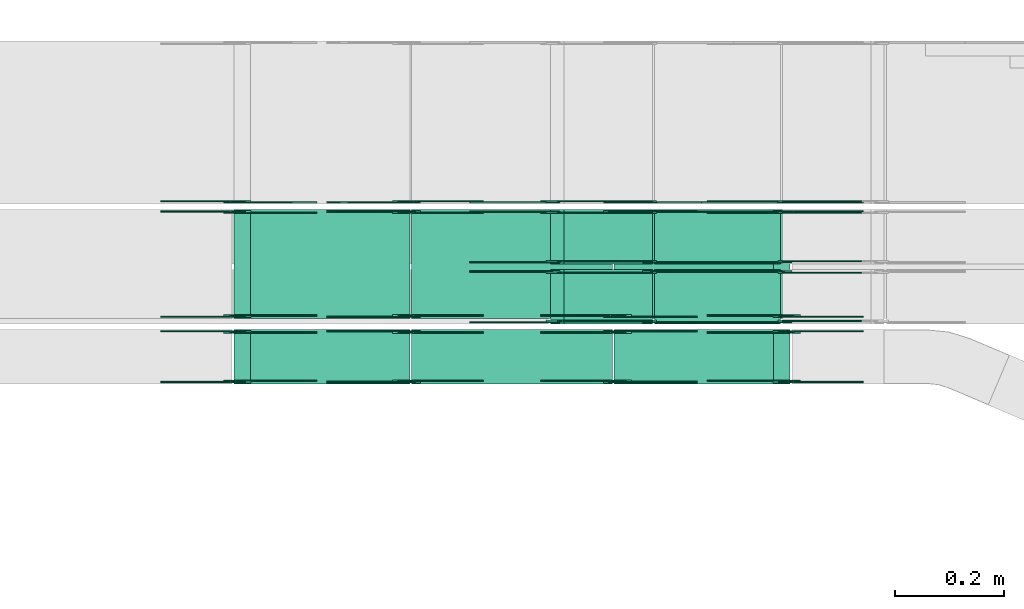
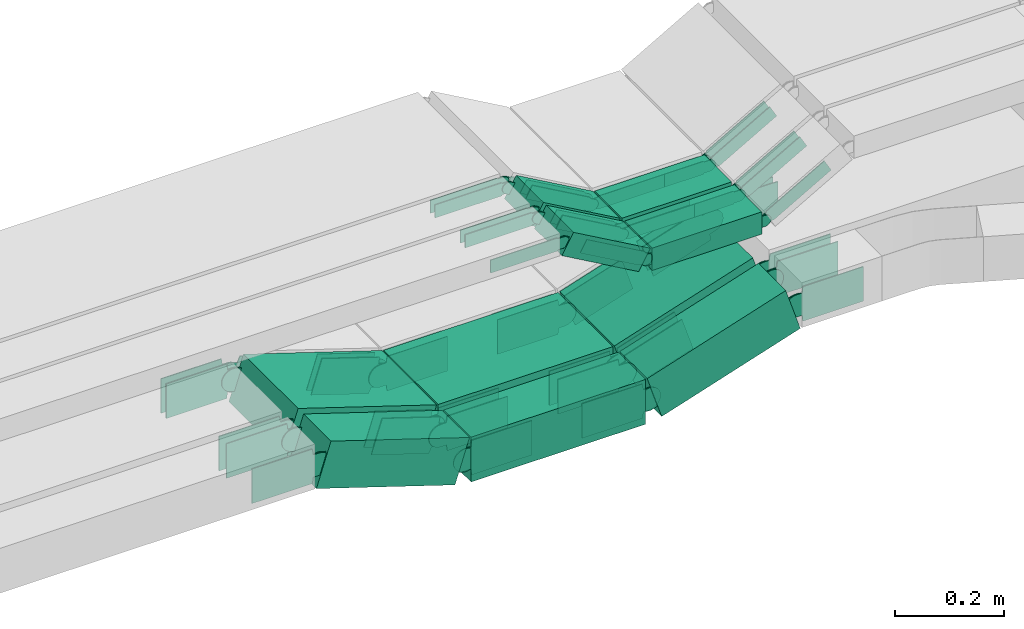
# One storey, part 11 of 28: 70 flow fittings, 10 flow segments.
"""IFC2X3 building model written with IfcOpenShell, lengths in millimetres."""

from ifc_helpers import new_model, entity, si_unit, converted_unit, derived_unit, direction, frame, frame_2d, origin, origin_2d_with_axis, place, context, subcontext, project, spatial, polyline, circle_curve, parameter, trimmed, segment, composite_curve, rectangle, outline, extrude, source, transform, mapped, material, type_object, type_shapes, element, save


model = new_model("IFC2X3")

# Units and contexts
model_context = context("Model", 3, precision=0.01, world=origin(), true_north=direction((6.12303176911189e-17, 1.0)))
body_context = subcontext(model_context, "Body", "Model", "MODEL_VIEW")
ifc_project = project(units=[si_unit("LENGTHUNIT", "METRE", prefix="MILLI"), si_unit("AREAUNIT", "SQUARE_METRE"), si_unit("VOLUMEUNIT", "CUBIC_METRE"), converted_unit("PLANEANGLEUNIT", "DEGREE", entity("IfcRatioMeasure", 0.0174532925199433), si_unit("PLANEANGLEUNIT", "RADIAN"), dimensions=[0, 0, 0, 0, 0, 0, 0]), si_unit("MASSUNIT", "GRAM", prefix="KILO"), derived_unit("MASSDENSITYUNIT", [(si_unit("MASSUNIT", "GRAM", prefix="KILO"), 1), (si_unit("LENGTHUNIT", "METRE"), -3)]), derived_unit("MOMENTOFINERTIAUNIT", [(si_unit("LENGTHUNIT", "METRE"), 4)]), si_unit("TIMEUNIT", "SECOND"), si_unit("FREQUENCYUNIT", "HERTZ"), si_unit("THERMODYNAMICTEMPERATUREUNIT", "DEGREE_CELSIUS"), derived_unit("THERMALTRANSMITTANCEUNIT", [(si_unit("MASSUNIT", "GRAM", prefix="KILO"), 1), (si_unit("THERMODYNAMICTEMPERATUREUNIT", "KELVIN"), -1), (si_unit("TIMEUNIT", "SECOND"), -3)]), derived_unit("VOLUMETRICFLOWRATEUNIT", [(si_unit("LENGTHUNIT", "METRE"), 3), (si_unit("TIMEUNIT", "SECOND"), -1)]), derived_unit("MASSFLOWRATEUNIT", [(si_unit("MASSUNIT", "GRAM", prefix="KILO"), 1), (si_unit("TIMEUNIT", "SECOND"), -1)]), derived_unit("ROTATIONALFREQUENCYUNIT", [(si_unit("TIMEUNIT", "SECOND"), -1)]), si_unit("ELECTRICCURRENTUNIT", "AMPERE"), si_unit("ELECTRICVOLTAGEUNIT", "VOLT"), si_unit("POWERUNIT", "WATT"), si_unit("FORCEUNIT", "NEWTON", prefix="KILO"), si_unit("ILLUMINANCEUNIT", "LUX"), si_unit("LUMINOUSFLUXUNIT", "LUMEN"), si_unit("LUMINOUSINTENSITYUNIT", "CANDELA"), derived_unit("USERDEFINED", [(si_unit("MASSUNIT", "GRAM", prefix="KILO"), -1), (si_unit("LENGTHUNIT", "METRE"), -2), (si_unit("TIMEUNIT", "SECOND"), 3), (si_unit("LUMINOUSFLUXUNIT", "LUMEN"), 1)]), derived_unit("LINEARVELOCITYUNIT", [(si_unit("LENGTHUNIT", "METRE"), 1), (si_unit("TIMEUNIT", "SECOND"), -1)]), si_unit("PRESSUREUNIT", "PASCAL"), derived_unit("USERDEFINED", [(si_unit("LENGTHUNIT", "METRE"), -2), (si_unit("MASSUNIT", "GRAM", prefix="KILO"), 1), (si_unit("TIMEUNIT", "SECOND"), -2)]), derived_unit("LINEARFORCEUNIT", [(si_unit("MASSUNIT", "GRAM", prefix="KILO"), 1), (si_unit("LENGTHUNIT", "METRE"), 1), (si_unit("TIMEUNIT", "SECOND"), -2), (si_unit("LENGTHUNIT", "METRE"), -1)]), derived_unit("PLANARFORCEUNIT", [(si_unit("MASSUNIT", "GRAM", prefix="KILO"), 1), (si_unit("LENGTHUNIT", "METRE"), 1), (si_unit("TIMEUNIT", "SECOND"), -2), (si_unit("LENGTHUNIT", "METRE"), -2)])], contexts=[model_context])

# Site, building, storey
site_placement = place(None, frame((0.0, -0.00077364408347762, 0.0)))
site = spatial("IfcSite", under=ifc_project, at=site_placement, CompositionType="ELEMENT")
building_placement = place(site_placement, origin())
building = spatial("IfcBuilding", under=site, at=building_placement, CompositionType="ELEMENT")
storey_placement = place(building_placement, origin())
storey = spatial("IfcBuildingStorey", under=building, at=storey_placement, CompositionType="ELEMENT", Elevation=0.0)

# Flow segments
cable_carrier_segment_type = type_object("IfcCableCarrierSegmentType", PredefinedType="CABLETRAYSEGMENT")
flow_segment_1_placement = place(storey_placement, frame((34617.9514531577, 8410.17178445353, 2505.31401087129)))
element("IfcFlowSegment", 1, at=flow_segment_1_placement, inside=storey, type_object=cable_carrier_segment_type, context=body_context, shape_type="SweptSolid", body=[
    extrude(rectangle(XDim=100.0, YDim=200.0, at=origin_2d_with_axis()), frame((15.3279852813534, 100.0, 47.592571554969), z_axis=(0.951851431099374, 0.0, 0.306559705626938), x_axis=(-0.306559705626938, 0.0, 0.951851431099374)), (0.0, 0.0, 1.0), 307.238144539815),
])
flow_segment_2_placement = place(storey_placement, frame((34246.1055828453, 8410.17178445353, 2500.0)))
element("IfcFlowSegment", 2, at=flow_segment_2_placement, inside=storey, type_object=cable_carrier_segment_type, context=body_context, shape_type="SweptSolid", body=[
    extrude(rectangle(XDim=368.667780058814, YDim=200.0, at=frame_2d((-2.17426077142591e-12, 0.0), x_axis=(1.0, 0.0))), frame((184.333890029409, 100.0, 0.0), z_axis=(0.0, 0.0, 1.0), x_axis=(-1.0, 0.0, 0.0)), (0.0, 0.0, 1.0), 100.000000000001),
])
flow_segment_3_placement = place(storey_placement, frame((33919.8264544605, 8410.17178445353, 2505.31401087129)))
element("IfcFlowSegment", 3, at=flow_segment_3_placement, inside=storey, type_object=cable_carrier_segment_type, context=body_context, shape_type="SweptSolid", body=[
    extrude(rectangle(XDim=100.0, YDim=200.0, at=frame_2d((0.0, 0.0), x_axis=(0.0, 1.0))), frame((15.3279852813534, 100.0, 141.779406702467), z_axis=(0.951851431099359, 0.0, -0.306559705626982), x_axis=(0.0, 1.0, 0.0)), (0.0, 0.0, 1.0), 307.2381445398),
])
flow_segment_4_placement = place(storey_placement, frame((34617.9514531577, 8290.00006103515, 2505.31401087129)))
element("IfcFlowSegment", 4, at=flow_segment_4_placement, inside=storey, type_object=cable_carrier_segment_type, context=body_context, shape_type="SweptSolid", body=[
    extrude(rectangle(XDim=99.9999999999997, YDim=99.9999999999989, at=frame_2d((2.59348098552437e-13, 0.0), x_axis=(1.0, 0.0))), frame((15.3279852813491, 50.0, 47.592571554969), z_axis=(0.951851431099373, 0.0, 0.306559705626939), x_axis=(-0.306559705626939, 0.0, 0.951851431099373)), (0.0, 0.0, 1.0), 307.238144539829),
])
flow_segment_5_placement = place(storey_placement, frame((34246.1055828453, 8290.00006103515, 2500.0)))
element("IfcFlowSegment", 5, at=flow_segment_5_placement, inside=storey, type_object=cable_carrier_segment_type, context=body_context, shape_type="SweptSolid", body=[
    extrude(rectangle(XDim=368.667780058814, YDim=99.9999999999989, at=frame_2d((-2.1600499167107e-12, 0.0), x_axis=(1.0, 0.0))), frame((184.333890029409, 50.0, 0.0), z_axis=(0.0, 0.0, 1.0), x_axis=(-1.0, 0.0, 0.0)), (0.0, 0.0, 1.0), 99.9999999999995),
])
flow_segment_6_placement = place(storey_placement, frame((33919.8264544606, 8290.00006103515, 2505.31401087129)))
element("IfcFlowSegment", 6, at=flow_segment_6_placement, inside=storey, type_object=cable_carrier_segment_type, context=body_context, shape_type="SweptSolid", body=[
    extrude(rectangle(XDim=99.9999999999985, YDim=99.9999999999989, at=frame_2d((0.0, 0.0), x_axis=(0.0, 1.0))), frame((15.3279852813534, 50.0, 141.779406702453), z_axis=(0.95185143109933, 0.0, -0.306559705627073), x_axis=(0.0, 1.0, 0.0)), (0.0, 0.0, 1.0), 307.238144539648),
])
flow_segment_7_placement = place(storey_placement, frame((34501.2194926149, 8400.00006103519, 2756.67195783193)))
element("IfcFlowSegment", 7, at=flow_segment_7_placement, inside=storey, type_object=cable_carrier_segment_type, context=body_context, shape_type="SweptSolid", body=[
    extrude(rectangle(XDim=49.999999999999, YDim=100.000000000001, at=frame_2d((-1.08002495835535e-12, -2.34479102800833e-13), x_axis=(0.0, 1.0))), frame((12.3695839738717, 50.0, 114.034733144907), z_axis=(0.869016356406197, 0.0, -0.494783358954703), x_axis=(0.0, 1.0, 0.0)), (0.0, 0.0, 1.0), 186.565135152812),
])
flow_segment_8_placement = place(storey_placement, frame((34691.9349643378, 8400.00006103519, 2749.10405771889)))
element("IfcFlowSegment", 8, at=flow_segment_8_placement, inside=storey, type_object=cable_carrier_segment_type, context=body_context, shape_type="SweptSolid", body=[
    extrude(rectangle(XDim=231.322850808314, YDim=100.000000000001, at=frame_2d((0.0, 5.43565192856477e-13), x_axis=(1.0, 0.0))), frame((115.661425404157, 50.0, 0.0)), (0.0, 0.0, 1.0), 49.9999999999989),
])
flow_segment_9_placement = place(storey_placement, frame((34501.2194926148, 8510.00006103507, 2756.67195783192)))
element("IfcFlowSegment", 9, at=flow_segment_9_placement, inside=storey, type_object=cable_carrier_segment_type, context=body_context, shape_type="SweptSolid", body=[
    extrude(rectangle(XDim=50.0000000000032, YDim=100.000000000001, at=frame_2d((1.08357767203415e-12, 0.0), x_axis=(0.0, 1.0))), frame((12.369583973863, 50.0, 114.034733144919), z_axis=(0.869016356406319, 0.0, -0.494783358954488), x_axis=(0.0, 1.0, 0.0)), (0.0, 0.0, 1.0), 186.565135152928),
])
flow_segment_10_placement = place(storey_placement, frame((34691.9349643378, 8510.00006103507, 2749.10405771889)))
element("IfcFlowSegment", 10, at=flow_segment_10_placement, inside=storey, type_object=cable_carrier_segment_type, context=body_context, shape_type="SweptSolid", body=[
    extrude(rectangle(XDim=231.322850808314, YDim=100.000000000001, at=frame_2d((0.0, 5.43565192856477e-13), x_axis=(1.0, 0.0))), frame((115.661425404157, 50.0, 0.0)), (0.0, 0.0, 1.0), 49.9999999999989),
])

# Flow fittings
ifc_material = material(Name="G")
cable_carrier_fitting_type_1 = type_object("IfcCableCarrierFittingType", PredefinedType="NOTDEFINED", material=ifc_material)
shared_shape_1 = source(origin(), body_context, "Body", "SweptSolid", [
    extrude(outline(composite_curve([segment(trimmed(circle_curve(frame_2d((-44.5901162790698, 0.0), x_axis=(1.0, 0.0)), 12.5), [parameter(90.0000000000007)], [parameter(270.0)], True, "PARAMETER"), True, "CONTINUOUS"), segment(polyline([(-44.5901162790697, -12.5), (-33.0901162790698, -12.5)]), True, "CONTINUOUS"), segment(polyline([(-33.0901162790698, -12.5), (-31.2296511627907, -14.5)]), True, "CONTINUOUS"), segment(polyline([(-31.2296511627907, -14.5), (108.90988372093, -14.5)]), True, "CONTINUOUS"), segment(polyline([(108.90988372093, -14.5), (108.90988372093, 14.5)]), True, "CONTINUOUS"), segment(polyline([(108.90988372093, 14.5), (-31.2296511627907, 14.5)]), True, "CONTINUOUS"), segment(polyline([(-31.2296511627907, 14.5), (-33.0901162790698, 12.5)]), True, "CONTINUOUS"), segment(polyline([(-33.0901162790698, 12.5), (-44.5901162790699, 12.5)]), True, "CONTINUOUS")], self_intersect=False)), frame((44.5901162790698, 0.0, 0.0), z_axis=(0.0, 0.0, -1.0), x_axis=(1.0, 0.0, 0.0)), (0.0, 0.0, -1.0), 2.0),
])
type_shapes(cable_carrier_fitting_type_1, [shared_shape_1])
for number, where, z_axis, x_axis in (
    (11, (34683.2578151462, 8404.54006102503, 2774.10405771888), (0.0, -1.0, 0.0), (1.0, 0.0, 0.0)),
    (12, (34931.9349643377, 8495.46006104535, 2774.10405771889), (0.0, 1.0, 0.0), (-1.0, 0.0, 0.0)),
    (13, (34683.2578151462, 8514.54006102491, 2774.10405771888), (0.0, -1.0, 0.0), (1.0, 0.0, 0.0)),
    (14, (34931.9349643377, 8605.46006104523, 2774.10405771889), (0.0, 1.0, 0.0), (-1.0, 0.0, 0.0)),
    (15, (34683.2578151462, 8624.54006102498, 2774.10405771888), (0.0, -1.0, 0.0), (1.0, 0.0, 0.0)),
    (16, (34506.0484920139, 8624.54006102498, 2875.0), (0.0, -1.0, 0.0), (-1.0, 0.0, 0.0)),
    (17, (34506.0484920142, 8514.54006102491, 2875.0), (0.0, -1.0, 0.0), (-1.0, 0.0, 0.0)),
    (18, (34506.0484920143, 8404.54006102503, 2875.0), (0.0, -1.0, 0.0), (-1.0, 0.0, 0.0)),
):
    element("IfcFlowFitting", number, at=place(storey_placement, frame(where, z_axis=z_axis, x_axis=x_axis)), inside=storey, type_object=cable_carrier_fitting_type_1, material=ifc_material, context=body_context, shape_type="MappedRepresentation", body=[
        mapped(shared_shape_1, transform((0.0, 0.0, 0.0), scale=1.0)),
    ])
cable_carrier_fitting_type_2 = type_object("IfcCableCarrierFittingType", PredefinedType="NOTDEFINED", material=ifc_material)
shared_shape_2 = source(origin(), body_context, "Body", "SweptSolid", [
    extrude(outline(composite_curve([segment(trimmed(circle_curve(frame_2d((-44.5901162790697, 0.0), x_axis=(1.0, 0.0)), 12.5), [parameter(90.0000000000007)], [parameter(270.0)], True, "PARAMETER"), True, "CONTINUOUS"), segment(polyline([(-44.5901162790697, -12.5), (-33.0901162790697, -12.5)]), True, "CONTINUOUS"), segment(polyline([(-33.0901162790697, -12.5), (-31.2296511627907, -14.5)]), True, "CONTINUOUS"), segment(polyline([(-31.2296511627907, -14.5), (108.90988372093, -14.5)]), True, "CONTINUOUS"), segment(polyline([(108.90988372093, -14.5), (108.90988372093, 14.5)]), True, "CONTINUOUS"), segment(polyline([(108.90988372093, 14.5), (-31.2296511627907, 14.5)]), True, "CONTINUOUS"), segment(polyline([(-31.2296511627907, 14.5), (-33.0901162790698, 12.5)]), True, "CONTINUOUS"), segment(polyline([(-33.0901162790698, 12.5), (-44.5901162790699, 12.5)]), True, "CONTINUOUS")], self_intersect=False)), frame((44.5901162790697, 0.0, 0.0)), (0.0, 0.0, 1.0), 2.0),
])
type_shapes(cable_carrier_fitting_type_2, [shared_shape_2])
for number, where, z_axis, x_axis in (
    (19, (34683.2578151462, 8495.46006104535, 2774.10405771888), (0.0, 1.0, 0.0), (1.0, 0.0, 0.0)),
    (20, (34931.9349643377, 8404.54006102503, 2774.10405771888), (0.0, -1.0, 0.0), (-1.0, 0.0, 0.0)),
    (21, (34683.2578151462, 8605.46006104523, 2774.10405771888), (0.0, 1.0, 0.0), (1.0, 0.0, 0.0)),
    (22, (34931.9349643377, 8514.54006102491, 2774.10405771888), (0.0, -1.0, 0.0), (-1.0, 0.0, 0.0)),
    (23, (34931.9349643377, 8624.54006102498, 2774.10405771889), (0.0, -1.0, 0.0), (-1.0, 0.0, 0.0)),
    (24, (34506.0484920142, 8605.46006104523, 2875.0), (0.0, 1.0, 0.0), (-1.0, 0.0, 0.0)),
    (25, (34506.0484920143, 8495.46006104535, 2875.0), (0.0, 1.0, 0.0), (-1.0, 0.0, 0.0)),
):
    element("IfcFlowFitting", number, at=place(storey_placement, frame(where, z_axis=z_axis, x_axis=x_axis)), inside=storey, type_object=cable_carrier_fitting_type_2, material=ifc_material, context=body_context, shape_type="MappedRepresentation", body=[
        mapped(shared_shape_2, transform((0.0, 0.0, 0.0), scale=1.0)),
    ])
cable_carrier_fitting_type_3 = type_object("IfcCableCarrierFittingType", PredefinedType="NOTDEFINED", material=ifc_material)
shared_shape_3 = source(origin(), body_context, "Body", "SweptSolid", [
    extrude(outline(composite_curve([segment(trimmed(circle_curve(frame_2d((-44.5901162790698, 0.0), x_axis=(1.0, 0.0)), 12.5), [parameter(90.0000000000007)], [parameter(270.0)], True, "PARAMETER"), True, "CONTINUOUS"), segment(polyline([(-44.5901162790697, -12.5), (-33.0901162790698, -12.5)]), True, "CONTINUOUS"), segment(polyline([(-33.0901162790698, -12.5), (-31.2296511627907, -14.5)]), True, "CONTINUOUS"), segment(polyline([(-31.2296511627907, -14.5), (108.90988372093, -14.5)]), True, "CONTINUOUS"), segment(polyline([(108.90988372093, -14.5), (108.90988372093, 14.5)]), True, "CONTINUOUS"), segment(polyline([(108.90988372093, 14.5), (-31.2296511627907, 14.5)]), True, "CONTINUOUS"), segment(polyline([(-31.2296511627907, 14.5), (-33.0901162790698, 12.5)]), True, "CONTINUOUS"), segment(polyline([(-33.0901162790698, 12.5), (-44.5901162790699, 12.5)]), True, "CONTINUOUS")], self_intersect=False)), frame((44.5901162790698, 0.0, 0.0), z_axis=(0.0, 0.0, -1.0), x_axis=(1.0, 0.0, 0.0)), (0.0, 0.0, -1.0), 2.0),
])
type_shapes(cable_carrier_fitting_type_3, [shared_shape_3])
for number, where, z_axis, x_axis in (
    (26, (34683.2578151462, 8493.46006104535, 2774.10405771887), (0.0, 1.0, 0.0), (-0.869016356406185, 0.0, 0.494783358954723)),
    (27, (34931.9349643377, 8406.54006102503, 2774.10405771888), (0.0, -1.0, 0.0), (0.869016356406185, 0.0, 0.494783358954723)),
    (28, (34683.2578151462, 8603.46006104523, 2774.10405771887), (0.0, 1.0, 0.0), (-0.869016356406185, 0.0, 0.494783358954723)),
    (29, (34931.9349643377, 8516.54006102491, 2774.10405771888), (0.0, -1.0, 0.0), (0.869016356406185, 0.0, 0.494783358954723)),
    (30, (34931.9349643377, 8626.54006102498, 2774.10405771888), (0.0, -1.0, 0.0), (0.869016356406185, 0.0, 0.494783358954723)),
    (31, (34506.0484920142, 8603.46006104523, 2875.0), (0.0, 1.0, 0.0), (0.869016356406338, 0.0, -0.494783358954455)),
    (32, (34506.0484920142, 8493.46006104535, 2875.0), (0.0, 1.0, 0.0), (0.869016356406185, 0.0, -0.494783358954723)),
):
    element("IfcFlowFitting", number, at=place(storey_placement, frame(where, z_axis=z_axis, x_axis=x_axis)), inside=storey, type_object=cable_carrier_fitting_type_3, material=ifc_material, context=body_context, shape_type="MappedRepresentation", body=[
        mapped(shared_shape_3, transform((0.0, 0.0, 0.0), scale=1.0)),
    ])
cable_carrier_fitting_type_4 = type_object("IfcCableCarrierFittingType", PredefinedType="NOTDEFINED", material=ifc_material)
shared_shape_4 = source(origin(), body_context, "Body", "SweptSolid", [
    extrude(outline(composite_curve([segment(trimmed(circle_curve(frame_2d((-44.5901162790697, 0.0), x_axis=(1.0, 0.0)), 12.5), [parameter(90.0000000000007)], [parameter(270.0)], True, "PARAMETER"), True, "CONTINUOUS"), segment(polyline([(-44.5901162790697, -12.5), (-33.0901162790697, -12.5)]), True, "CONTINUOUS"), segment(polyline([(-33.0901162790697, -12.5), (-31.2296511627907, -14.5)]), True, "CONTINUOUS"), segment(polyline([(-31.2296511627907, -14.5), (108.90988372093, -14.5)]), True, "CONTINUOUS"), segment(polyline([(108.90988372093, -14.5), (108.90988372093, 14.5)]), True, "CONTINUOUS"), segment(polyline([(108.90988372093, 14.5), (-31.2296511627907, 14.5)]), True, "CONTINUOUS"), segment(polyline([(-31.2296511627907, 14.5), (-33.0901162790698, 12.5)]), True, "CONTINUOUS"), segment(polyline([(-33.0901162790698, 12.5), (-44.5901162790699, 12.5)]), True, "CONTINUOUS")], self_intersect=False)), frame((44.5901162790697, 0.0, 0.0)), (0.0, 0.0, 1.0), 2.0),
])
type_shapes(cable_carrier_fitting_type_4, [shared_shape_4])
for number, where, z_axis, x_axis in (
    (33, (34683.2578151462, 8406.54006102503, 2774.10405771888), (0.0, -1.0, 0.0), (-0.869016356406185, 0.0, 0.494783358954723)),
    (34, (34931.9349643377, 8493.46006104534, 2774.10405771889), (0.0, 1.0, 0.0), (0.869016356406185, 0.0, 0.494783358954723)),
    (35, (34683.2578151462, 8516.54006102491, 2774.10405771888), (0.0, -1.0, 0.0), (-0.869016356406185, 0.0, 0.494783358954723)),
    (36, (34931.9349643377, 8603.46006104522, 2774.10405771889), (0.0, 1.0, 0.0), (0.869016356406185, 0.0, 0.494783358954723)),
    (37, (34683.2578151462, 8626.54006102498, 2774.10405771888), (0.0, -1.0, 0.0), (-0.869016356406185, 0.0, 0.494783358954723)),
    (38, (34506.0484920139, 8626.54006102499, 2875.0), (0.0, -1.0, 0.0), (0.869016356406536, 0.0, -0.494783358954106)),
    (39, (34506.0484920142, 8516.54006102491, 2875.0), (0.0, -1.0, 0.0), (0.869016356406338, 0.0, -0.494783358954455)),
    (40, (34506.0484920142, 8406.54006102503, 2875.0), (0.0, -1.0, 0.0), (0.869016356406185, 0.0, -0.494783358954723)),
):
    element("IfcFlowFitting", number, at=place(storey_placement, frame(where, z_axis=z_axis, x_axis=x_axis)), inside=storey, type_object=cable_carrier_fitting_type_4, material=ifc_material, context=body_context, shape_type="MappedRepresentation", body=[
        mapped(shared_shape_4, transform((0.0, 0.0, 0.0), scale=1.0)),
    ])
cable_carrier_fitting_type_5 = type_object("IfcCableCarrierFittingType", PredefinedType="NOTDEFINED", material=ifc_material)
shared_shape_5 = source(origin(), body_context, "Body", "SweptSolid", [
    extrude(outline(composite_curve([segment(trimmed(circle_curve(frame_2d((-41.4651162790697, 0.0), x_axis=(1.0, 0.0)), 25.0), [parameter(90.0000000000007)], [parameter(270.0)], True, "PARAMETER"), True, "CONTINUOUS"), segment(polyline([(-41.4651162790697, -25.0), (-29.9651162790697, -25.0)]), True, "CONTINUOUS"), segment(polyline([(-29.9651162790697, -25.0), (-28.1046511627907, -38.5)]), True, "CONTINUOUS"), segment(polyline([(-28.1046511627907, -38.5), (99.5348837209303, -38.5)]), True, "CONTINUOUS"), segment(polyline([(99.5348837209303, -38.5), (99.5348837209303, 38.5)]), True, "CONTINUOUS"), segment(polyline([(99.5348837209303, 38.5), (-28.1046511627907, 38.5)]), True, "CONTINUOUS"), segment(polyline([(-28.1046511627907, 38.5), (-29.9651162790697, 25.0)]), True, "CONTINUOUS"), segment(polyline([(-29.9651162790697, 25.0), (-41.46511627907, 25.0)]), True, "CONTINUOUS")], self_intersect=False)), frame((41.4651162790697, 0.0, 0.0), z_axis=(0.0, 0.0, -1.0), x_axis=(1.0, 0.0, 0.0)), (0.0, 0.0, -1.0), 2.0),
])
type_shapes(cable_carrier_fitting_type_5, [shared_shape_5])
for number, where, z_axis, x_axis in (
    (41, (34624.254656019, 8624.54006102506, 2550.0), (0.0, -1.0, 0.0), (0.951851431099356, 0.0, 0.306559705626994)),
    (42, (34624.254656019, 8414.71178444337, 2550.0), (0.0, -1.0, 0.0), (0.951851431099356, 0.0, 0.306559705626994)),
    (43, (34236.6242897305, 8605.63178446369, 2550.0), (0.0, 1.0, 0.0), (-0.951851431099356, 0.0, 0.306559705626994)),
    (44, (34624.254656019, 8294.54006102499, 2550.0), (0.0, -1.0, 0.0), (0.951851431099356, 0.0, 0.306559705626994)),
    (45, (34236.6242897305, 8385.46006104531, 2550.0), (0.0, 1.0, 0.0), (-0.951851431099356, 0.0, 0.306559705626994)),
    (46, (34934.7492884277, 8385.46006104531, 2650.0), (0.0, 1.0, 0.0), (1.0, 0.0, 0.0)),
    (47, (34934.7492884277, 8605.63178446369, 2650.0), (0.0, 1.0, 0.0), (1.0, 0.0, 0.0)),
    (48, (33926.1296573218, 8414.71178444338, 2650.0), (0.0, -1.0, 0.0), (-1.0, 0.0, 0.0)),
    (49, (33926.1296573219, 8294.54006102499, 2650.0), (0.0, -1.0, 0.0), (-1.0, 0.0, 0.0)),
):
    element("IfcFlowFitting", number, at=place(storey_placement, frame(where, z_axis=z_axis, x_axis=x_axis)), inside=storey, type_object=cable_carrier_fitting_type_5, material=ifc_material, context=body_context, shape_type="MappedRepresentation", body=[
        mapped(shared_shape_5, transform((0.0, 0.0, 0.0), scale=1.0)),
    ])
cable_carrier_fitting_type_6 = type_object("IfcCableCarrierFittingType", PredefinedType="NOTDEFINED", material=ifc_material)
shared_shape_6 = source(origin(), body_context, "Body", "SweptSolid", [
    extrude(outline(composite_curve([segment(trimmed(circle_curve(frame_2d((-41.4651162790697, 0.0), x_axis=(1.0, 0.0)), 25.0), [parameter(90.0000000000007)], [parameter(270.0)], True, "PARAMETER"), True, "CONTINUOUS"), segment(polyline([(-41.4651162790697, -25.0), (-29.9651162790697, -25.0)]), True, "CONTINUOUS"), segment(polyline([(-29.9651162790697, -25.0), (-28.1046511627907, -38.5)]), True, "CONTINUOUS"), segment(polyline([(-28.1046511627907, -38.5), (99.5348837209303, -38.5)]), True, "CONTINUOUS"), segment(polyline([(99.5348837209303, -38.5), (99.5348837209303, 38.5)]), True, "CONTINUOUS"), segment(polyline([(99.5348837209303, 38.5), (-28.1046511627907, 38.5)]), True, "CONTINUOUS"), segment(polyline([(-28.1046511627907, 38.5), (-29.9651162790697, 25.0)]), True, "CONTINUOUS"), segment(polyline([(-29.9651162790697, 25.0), (-41.46511627907, 25.0)]), True, "CONTINUOUS")], self_intersect=False)), frame((41.4651162790697, 0.0, 0.0)), (0.0, 0.0, 1.0), 2.0),
])
type_shapes(cable_carrier_fitting_type_6, [shared_shape_6])
for number, where, z_axis, x_axis in (
    (50, (33926.1296573219, 8624.54006102507, 2650.0), (0.0, -1.0, 0.0), (0.951851431099356, 0.0, -0.306559705626994)),
    (51, (34236.6242897305, 8624.54006102506, 2550.0), (0.0, -1.0, 0.0), (-0.951851431099356, 0.0, 0.306559705626994)),
    (52, (34624.254656019, 8605.63178446369, 2550.0), (0.0, 1.0, 0.0), (0.951851431099356, 0.0, 0.306559705626994)),
    (53, (34236.6242897305, 8414.71178444337, 2550.0), (0.0, -1.0, 0.0), (-0.951851431099356, 0.0, 0.306559705626994)),
    (54, (34624.254656019, 8385.46006104531, 2550.0), (0.0, 1.0, 0.0), (0.951851431099356, 0.0, 0.306559705626994)),
    (55, (34236.6242897305, 8294.54006102499, 2550.0), (0.0, -1.0, 0.0), (-0.951851431099356, 0.0, 0.306559705626994)),
    (56, (34934.7492884277, 8294.54006102499, 2650.0), (0.0, -1.0, 0.0), (1.0, 0.0, 0.0)),
    (57, (34934.7492884277, 8414.71178444337, 2650.0), (0.0, -1.0, 0.0), (1.0, 0.0, 0.0)),
    (58, (34934.7492884276, 8624.54006102507, 2650.0), (0.0, -1.0, 0.0), (1.0, 0.0, 0.0)),
    (59, (33926.1296573218, 8605.63178446369, 2650.0), (0.0, 1.0, 0.0), (-1.0, 0.0, 0.0)),
    (60, (33926.1296573219, 8385.46006104531, 2650.0), (0.0, 1.0, 0.0), (-1.0, 0.0, 0.0)),
):
    element("IfcFlowFitting", number, at=place(storey_placement, frame(where, z_axis=z_axis, x_axis=x_axis)), inside=storey, type_object=cable_carrier_fitting_type_6, material=ifc_material, context=body_context, shape_type="MappedRepresentation", body=[
        mapped(shared_shape_6, transform((0.0, 0.0, 0.0), scale=1.0)),
    ])
cable_carrier_fitting_type_7 = type_object("IfcCableCarrierFittingType", PredefinedType="NOTDEFINED", material=ifc_material)
shared_shape_7 = source(origin(), body_context, "Body", "SweptSolid", [
    extrude(outline(composite_curve([segment(trimmed(circle_curve(frame_2d((-41.4651162790697, 0.0), x_axis=(1.0, 0.0)), 25.0), [parameter(90.0000000000007)], [parameter(270.0)], True, "PARAMETER"), True, "CONTINUOUS"), segment(polyline([(-41.4651162790697, -25.0), (-29.9651162790697, -25.0)]), True, "CONTINUOUS"), segment(polyline([(-29.9651162790697, -25.0), (-28.1046511627907, -38.5)]), True, "CONTINUOUS"), segment(polyline([(-28.1046511627907, -38.5), (99.5348837209303, -38.5)]), True, "CONTINUOUS"), segment(polyline([(99.5348837209303, -38.5), (99.5348837209303, 38.5)]), True, "CONTINUOUS"), segment(polyline([(99.5348837209303, 38.5), (-28.1046511627907, 38.5)]), True, "CONTINUOUS"), segment(polyline([(-28.1046511627907, 38.5), (-29.9651162790697, 25.0)]), True, "CONTINUOUS"), segment(polyline([(-29.9651162790697, 25.0), (-41.46511627907, 25.0)]), True, "CONTINUOUS")], self_intersect=False)), frame((41.4651162790697, 0.0, 0.0), z_axis=(0.0, 0.0, -1.0), x_axis=(1.0, 0.0, 0.0)), (0.0, 0.0, -1.0), 2.0),
])
type_shapes(cable_carrier_fitting_type_7, [shared_shape_7])
for number, where, z_axis, x_axis in (
    (61, (33926.1296573219, 8626.54006102506, 2650.0), (0.0, -1.0, 0.0), (-1.0, 0.0, 0.0)),
    (62, (34236.6242897304, 8626.54006102506, 2550.0), (0.0, -1.0, 0.0), (1.0, 0.0, 0.0)),
    (63, (34624.254656019, 8603.63178446369, 2550.0), (0.0, 1.0, 0.0), (-1.0, 0.0, 0.0)),
    (64, (34236.6242897304, 8416.71178444337, 2550.0), (0.0, -1.0, 0.0), (1.0, 0.0, 0.0)),
    (65, (34624.254656019, 8383.46006104531, 2550.0), (0.0, 1.0, 0.0), (-1.0, 0.0, 0.0)),
    (66, (34236.6242897304, 8296.54006102499, 2550.0), (0.0, -1.0, 0.0), (1.0, 0.0, 0.0)),
    (67, (34934.7492884277, 8296.54006102499, 2650.0), (0.0, -1.0, 0.0), (-0.951851431099383, 0.0, -0.306559705626907)),
    (68, (34934.7492884277, 8416.71178444337, 2650.0), (0.0, -1.0, 0.0), (-0.951851431099383, 0.0, -0.306559705626908)),
    (69, (34934.7492884276, 8626.54006102506, 2650.0), (0.0, -1.0, 0.0), (-0.951851431099383, 0.0, -0.306559705626908)),
    (70, (33926.1296573218, 8603.63178446369, 2650.0), (0.0, 1.0, 0.0), (0.951851431099373, 0.0, -0.306559705626939)),
    (71, (33926.1296573219, 8383.46006104531, 2650.0), (0.0, 1.0, 0.0), (0.951851431099337, 0.0, -0.306559705627052)),
):
    element("IfcFlowFitting", number, at=place(storey_placement, frame(where, z_axis=z_axis, x_axis=x_axis)), inside=storey, type_object=cable_carrier_fitting_type_7, material=ifc_material, context=body_context, shape_type="MappedRepresentation", body=[
        mapped(shared_shape_7, transform((0.0, 0.0, 0.0), scale=1.0)),
    ])
cable_carrier_fitting_type_8 = type_object("IfcCableCarrierFittingType", PredefinedType="NOTDEFINED", material=ifc_material)
shared_shape_8 = source(origin(), body_context, "Body", "SweptSolid", [
    extrude(outline(composite_curve([segment(trimmed(circle_curve(frame_2d((-41.4651162790697, 0.0), x_axis=(1.0, 0.0)), 25.0), [parameter(90.0000000000007)], [parameter(270.0)], True, "PARAMETER"), True, "CONTINUOUS"), segment(polyline([(-41.4651162790697, -25.0), (-29.9651162790697, -25.0)]), True, "CONTINUOUS"), segment(polyline([(-29.9651162790697, -25.0), (-28.1046511627907, -38.5)]), True, "CONTINUOUS"), segment(polyline([(-28.1046511627907, -38.5), (99.5348837209303, -38.5)]), True, "CONTINUOUS"), segment(polyline([(99.5348837209303, -38.5), (99.5348837209303, 38.5)]), True, "CONTINUOUS"), segment(polyline([(99.5348837209303, 38.5), (-28.1046511627907, 38.5)]), True, "CONTINUOUS"), segment(polyline([(-28.1046511627907, 38.5), (-29.9651162790697, 25.0)]), True, "CONTINUOUS"), segment(polyline([(-29.9651162790697, 25.0), (-41.46511627907, 25.0)]), True, "CONTINUOUS")], self_intersect=False)), frame((41.4651162790697, 0.0, 0.0)), (0.0, 0.0, 1.0), 2.0),
])
type_shapes(cable_carrier_fitting_type_8, [shared_shape_8])
for number, where, z_axis, x_axis in (
    (72, (34624.254656019, 8626.54006102506, 2550.0), (0.0, -1.0, 0.0), (-1.0, 0.0, 0.0)),
    (73, (34624.254656019, 8416.71178444337, 2550.0), (0.0, -1.0, 0.0), (-1.0, 0.0, 0.0)),
    (74, (34236.6242897304, 8603.63178446369, 2550.0), (0.0, 1.0, 0.0), (1.0, 0.0, 0.0)),
    (75, (34624.254656019, 8296.54006102499, 2550.0), (0.0, -1.0, 0.0), (-1.0, 0.0, 0.0)),
    (76, (34236.6242897304, 8383.46006104531, 2550.0), (0.0, 1.0, 0.0), (1.0, 0.0, 0.0)),
    (77, (34934.7492884277, 8383.46006104531, 2650.0), (0.0, 1.0, 0.0), (-0.951851431099383, 0.0, -0.306559705626907)),
    (78, (34934.7492884277, 8603.63178446369, 2650.0), (0.0, 1.0, 0.0), (-0.951851431099383, 0.0, -0.306559705626908)),
    (79, (33926.1296573218, 8416.71178444338, 2650.0), (0.0, -1.0, 0.0), (0.951851431099373, 0.0, -0.306559705626939)),
    (80, (33926.1296573219, 8296.540061025, 2650.0), (0.0, -1.0, 0.0), (0.951851431099337, 0.0, -0.306559705627052)),
):
    element("IfcFlowFitting", number, at=place(storey_placement, frame(where, z_axis=z_axis, x_axis=x_axis)), inside=storey, type_object=cable_carrier_fitting_type_8, material=ifc_material, context=body_context, shape_type="MappedRepresentation", body=[
        mapped(shared_shape_8, transform((0.0, 0.0, 0.0), scale=1.0)),
    ])

save(model, "model.ifc")
